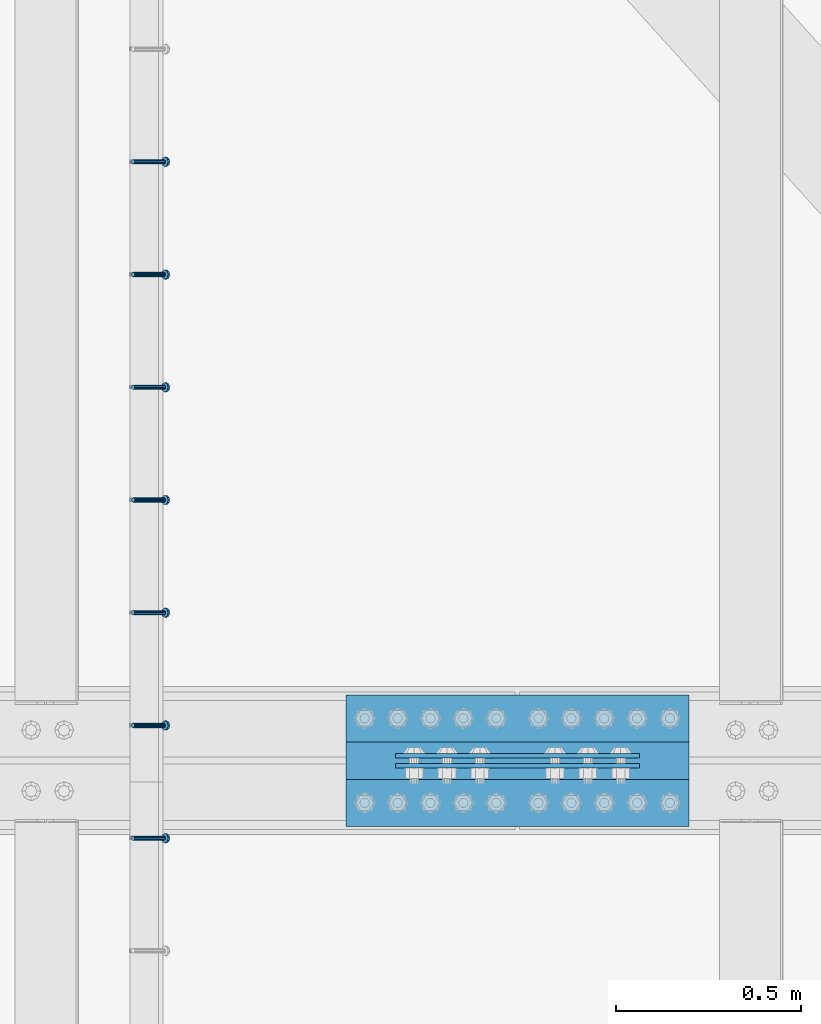
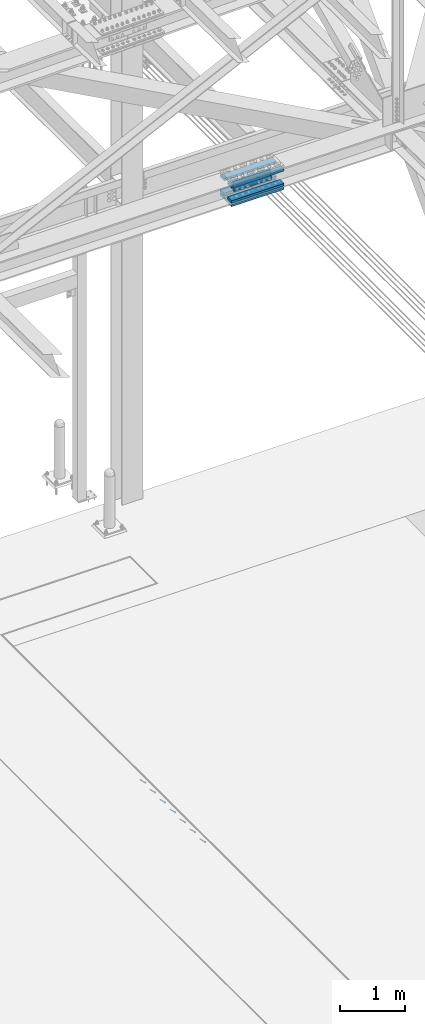
# One storey, part 2527 of 3843: 7 beams, 7 members, 3 elements without a shape of their own.
"""IFC2X3 building model written with IfcOpenShell, lengths in millimetres."""

from ifc_helpers import new_model, si_unit, frame, origin_with_axes, place, context, subcontext, project, spatial, faceted_brep, material, type_object, element, aggregate, save


model = new_model("IFC2X3")

# Units and contexts
model_context = context("Model", 3, precision=1e-05, world=origin_with_axes())
body_context = subcontext(model_context, "Body", "Model", "MODEL_VIEW")
ifc_project = project(units=[si_unit("LENGTHUNIT", "METRE", prefix="MILLI"), si_unit("AREAUNIT", "SQUARE_METRE"), si_unit("VOLUMEUNIT", "CUBIC_METRE"), si_unit("MASSUNIT", "GRAM", prefix="KILO"), si_unit("TIMEUNIT", "SECOND"), si_unit("PLANEANGLEUNIT", "RADIAN"), si_unit("SOLIDANGLEUNIT", "STERADIAN"), si_unit("THERMODYNAMICTEMPERATUREUNIT", "DEGREE_CELSIUS"), si_unit("LUMINOUSINTENSITYUNIT", "LUMEN")], contexts=[model_context])

# Site, building, storey
site_placement = place(None, origin_with_axes())
site = spatial("IfcSite", under=ifc_project, at=site_placement, CompositionType="ELEMENT")
building_placement = place(site_placement, origin_with_axes())
building = spatial("IfcBuilding", under=site, at=building_placement, Name="Undefined", CompositionType="ELEMENT")
storey_placement = place(building_placement, origin_with_axes())
storey = spatial("IfcBuildingStorey", under=building, at=storey_placement, Name="Undefined", CompositionType="ELEMENT", Elevation=0.0)

# Assembly, member
assembly_1_placement = place(storey_placement, origin_with_axes())
assembly_1 = element("IfcElementAssembly", 1, at=assembly_1_placement, inside=storey, Name="EMBED_ANGLE", AssemblyPlace="NOTDEFINED", PredefinedType="RIGID_FRAME")
ifc_material_1 = material(Name="STEEL/A108")
member_type = type_object("IfcMemberType", PredefinedType="NOTDEFINED")
member_1_placement = place(assembly_1_placement, frame((66677.3495, 83775.4227092285, 30446.6625), z_axis=(0.0, 1.0, 0.0), x_axis=(0.707106781186548, 0.0, -0.707106781186548)))
member_1 = element("IfcMember", 2, at=member_1_placement, type_object=member_type, material=ifc_material_1, Name="HEADED STUD ANCHOR", context=body_context, shape_type="Brep", body=[
    faceted_brep([(7.27595761418343e-12, -3.18000006675175, 5.5), (0.0, -5.49999999998363, 3.1800000667572), (118.110000000976, -5.49999999999091, 3.1800000667572), (118.110000000983, -3.18000006675175, 5.5), (0.0, -6.3499999046162, 0.0), (118.110000000968, -6.34999990461256, 0.0), (0.0, -5.49999999998363, -3.1800000667572), (118.110000000976, -5.49999999999091, -3.1800000667572), (7.27595761418343e-12, -3.18000006675175, -5.5), (118.110000000983, -3.18000006675175, -5.5), (7.27595761418343e-12, -1.81898940354586e-12, -6.34999990463257), (118.110000000968, -1.81898940354586e-12, -6.34999990463257), (0.0, 3.18000006675175, -5.5), (118.110000000968, 3.18000006674811, -5.5), (7.27595761418343e-12, 5.49999999998363, -3.1800000667572), (118.110000000983, 5.49999999998363, -3.1800000667572), (7.27595761418343e-12, 6.3499999046162, 0.0), (118.110000000976, 6.34999990461256, 0.0), (7.27595761418343e-12, 5.49999999998363, 3.1800000667572), (118.110000000983, 5.49999999998363, 3.1800000667572), (0.0, 3.18000006675175, 5.5), (118.110000000968, 3.18000006674811, 5.5), (7.27595761418343e-12, -1.81898940354586e-12, 6.34999990463257), (118.110000000968, -1.81898940354586e-12, 6.34999990463257), (120.650000000991, -10.9899997710909, 6.34999990463257), (120.650000000998, -6.34000015257152, 10.9899997711182), (120.650000000991, -12.6999998092379, 0.0), (120.650000000991, -10.9899997710909, -6.34999990463257), (120.650000000998, -6.34000015257152, -10.9899997711182), (120.650000000991, -1.81898940354586e-12, -12.6899995803833), (120.650000000991, 6.34000015257152, -10.9899997711182), (120.650000000998, 10.9899997710909, -6.34999990463257), (120.650000000991, 12.6999998092342, 0.0), (120.650000000998, 10.9899997710909, 6.34999990463257), (120.650000000991, 6.34000015257152, 10.9899997711182), (120.650000000991, -1.81898940354586e-12, 12.6899995803833), (127.000000001048, -10.9899997710945, 6.34999990463257), (127.000000001048, -6.34000015257152, 10.9899997711182), (127.000000001048, -12.6999998092342, 0.0), (127.000000001048, -10.9899997710945, -6.34999990463257), (127.000000001048, -6.34000015257152, -10.9899997711182), (127.000000001048, 1.81898940354586e-12, -12.6899995803833), (127.000000001048, 6.34000015256788, -10.9899997711182), (127.000000001048, 10.9899997710909, -6.34999990463257), (127.000000001048, 12.6999998092379, 0.0), (127.000000001048, 10.9899997710909, 6.34999990463257), (127.000000001048, 6.34000015256788, 10.9899997711182), (127.000000001048, 1.81898940354586e-12, 12.6899995803833)], [[[0, 1, 2, 3]], [[1, 4, 5, 2]], [[4, 6, 7, 5]], [[6, 8, 9, 7]], [[8, 10, 11, 9]], [[10, 12, 13, 11]], [[12, 14, 15, 13]], [[14, 16, 17, 15]], [[16, 18, 19, 17]], [[18, 20, 21, 19]], [[20, 22, 23, 21]], [[22, 0, 3, 23]], [[22, 20, 18, 16, 14, 12, 10, 8, 6, 4, 1, 0]], [[3, 2, 24, 25]], [[2, 5, 26, 24]], [[5, 7, 27, 26]], [[7, 9, 28, 27]], [[9, 11, 29, 28]], [[11, 13, 30, 29]], [[13, 15, 31, 30]], [[15, 17, 32, 31]], [[17, 19, 33, 32]], [[19, 21, 34, 33]], [[21, 23, 35, 34]], [[23, 3, 25, 35]], [[25, 24, 36, 37]], [[24, 26, 38, 36]], [[26, 27, 39, 38]], [[27, 28, 40, 39]], [[28, 29, 41, 40]], [[29, 30, 42, 41]], [[30, 31, 43, 42]], [[31, 32, 44, 43]], [[32, 33, 45, 44]], [[33, 34, 46, 45]], [[34, 35, 47, 46]], [[35, 25, 37, 47]], [[38, 39, 40, 41, 42, 43, 44, 45, 46, 47, 37, 36]]]),
])
aggregate(assembly_1, [member_1])

# Assembly, members
assembly_2_placement = place(storey_placement, origin_with_axes())
assembly_2 = element("IfcElementAssembly", 3, at=assembly_2_placement, inside=storey, Name="EMBED_ANGLE", AssemblyPlace="NOTDEFINED", PredefinedType="RIGID_FRAME")
member_2_placement = place(assembly_2_placement, frame((66677.3495, 84080.2227092285, 30446.6625), z_axis=(0.0, 1.0, 0.0), x_axis=(0.707106781186548, 0.0, -0.707106781186548)))
member_2 = element("IfcMember", 4, at=member_2_placement, type_object=member_type, material=ifc_material_1, Name="HEADED STUD ANCHOR", context=body_context, shape_type="Brep", body=[
    faceted_brep([(7.27595761418343e-12, -3.18000006675175, 5.5), (0.0, -5.49999999998363, 3.1800000667572), (118.110000000976, -5.49999999999091, 3.1800000667572), (118.110000000983, -3.18000006675175, 5.5), (0.0, -6.3499999046162, 0.0), (118.110000000968, -6.34999990461256, 0.0), (0.0, -5.49999999998363, -3.1800000667572), (118.110000000976, -5.49999999999091, -3.1800000667572), (7.27595761418343e-12, -3.18000006675175, -5.5), (118.110000000983, -3.18000006675175, -5.5), (7.27595761418343e-12, -1.81898940354586e-12, -6.34999990463257), (118.110000000968, -1.81898940354586e-12, -6.34999990463257), (0.0, 3.18000006675175, -5.5), (118.110000000968, 3.18000006674811, -5.5), (7.27595761418343e-12, 5.49999999998363, -3.1800000667572), (118.110000000983, 5.49999999998363, -3.1800000667572), (7.27595761418343e-12, 6.3499999046162, 0.0), (118.110000000976, 6.34999990461256, 0.0), (7.27595761418343e-12, 5.49999999998363, 3.1800000667572), (118.110000000983, 5.49999999998363, 3.1800000667572), (0.0, 3.18000006675175, 5.5), (118.110000000968, 3.18000006674811, 5.5), (7.27595761418343e-12, -1.81898940354586e-12, 6.34999990463257), (118.110000000968, -1.81898940354586e-12, 6.34999990463257), (120.650000000991, -10.9899997710909, 6.34999990463257), (120.650000000998, -6.34000015257152, 10.9899997711182), (120.650000000991, -12.6999998092379, 0.0), (120.650000000991, -10.9899997710909, -6.34999990463257), (120.650000000998, -6.34000015257152, -10.9899997711182), (120.650000000991, -1.81898940354586e-12, -12.6899995803833), (120.650000000991, 6.34000015257152, -10.9899997711182), (120.650000000998, 10.9899997710909, -6.34999990463257), (120.650000000991, 12.6999998092342, 0.0), (120.650000000998, 10.9899997710909, 6.34999990463257), (120.650000000991, 6.34000015257152, 10.9899997711182), (120.650000000991, -1.81898940354586e-12, 12.6899995803833), (127.000000001048, -10.9899997710945, 6.34999990463257), (127.000000001048, -6.34000015257152, 10.9899997711182), (127.000000001048, -12.6999998092342, 0.0), (127.000000001048, -10.9899997710945, -6.34999990463257), (127.000000001048, -6.34000015257152, -10.9899997711182), (127.000000001048, 1.81898940354586e-12, -12.6899995803833), (127.000000001048, 6.34000015256788, -10.9899997711182), (127.000000001048, 10.9899997710909, -6.34999990463257), (127.000000001048, 12.6999998092379, 0.0), (127.000000001048, 10.9899997710909, 6.34999990463257), (127.000000001048, 6.34000015256788, 10.9899997711182), (127.000000001048, 1.81898940354586e-12, 12.6899995803833)], [[[0, 1, 2, 3]], [[1, 4, 5, 2]], [[4, 6, 7, 5]], [[6, 8, 9, 7]], [[8, 10, 11, 9]], [[10, 12, 13, 11]], [[12, 14, 15, 13]], [[14, 16, 17, 15]], [[16, 18, 19, 17]], [[18, 20, 21, 19]], [[20, 22, 23, 21]], [[22, 0, 3, 23]], [[22, 20, 18, 16, 14, 12, 10, 8, 6, 4, 1, 0]], [[3, 2, 24, 25]], [[2, 5, 26, 24]], [[5, 7, 27, 26]], [[7, 9, 28, 27]], [[9, 11, 29, 28]], [[11, 13, 30, 29]], [[13, 15, 31, 30]], [[15, 17, 32, 31]], [[17, 19, 33, 32]], [[19, 21, 34, 33]], [[21, 23, 35, 34]], [[23, 3, 25, 35]], [[25, 24, 36, 37]], [[24, 26, 38, 36]], [[26, 27, 39, 38]], [[27, 28, 40, 39]], [[28, 29, 41, 40]], [[29, 30, 42, 41]], [[30, 31, 43, 42]], [[31, 32, 44, 43]], [[32, 33, 45, 44]], [[33, 34, 46, 45]], [[34, 35, 47, 46]], [[35, 25, 37, 47]], [[38, 39, 40, 41, 42, 43, 44, 45, 46, 47, 37, 36]]]),
])
member_3_placement = place(assembly_2_placement, frame((66677.3495, 84385.0227092285, 30446.6625), z_axis=(0.0, 1.0, 0.0), x_axis=(0.707106781186548, 0.0, -0.707106781186548)))
member_3 = element("IfcMember", 5, at=member_3_placement, type_object=member_type, material=ifc_material_1, Name="HEADED STUD ANCHOR", context=body_context, shape_type="Brep", body=[
    faceted_brep([(7.27595761418343e-12, -3.18000006675175, 5.5), (0.0, -5.49999999998363, 3.1800000667572), (118.110000000976, -5.49999999999091, 3.1800000667572), (118.110000000983, -3.18000006675175, 5.5), (0.0, -6.3499999046162, 0.0), (118.110000000968, -6.34999990461256, 0.0), (0.0, -5.49999999998363, -3.1800000667572), (118.110000000976, -5.49999999999091, -3.1800000667572), (7.27595761418343e-12, -3.18000006675175, -5.5), (118.110000000983, -3.18000006675175, -5.5), (7.27595761418343e-12, -1.81898940354586e-12, -6.34999990463257), (118.110000000968, -1.81898940354586e-12, -6.34999990463257), (0.0, 3.18000006675175, -5.5), (118.110000000968, 3.18000006674811, -5.5), (7.27595761418343e-12, 5.49999999998363, -3.1800000667572), (118.110000000983, 5.49999999998363, -3.1800000667572), (7.27595761418343e-12, 6.3499999046162, 0.0), (118.110000000976, 6.34999990461256, 0.0), (7.27595761418343e-12, 5.49999999998363, 3.1800000667572), (118.110000000983, 5.49999999998363, 3.1800000667572), (0.0, 3.18000006675175, 5.5), (118.110000000968, 3.18000006674811, 5.5), (7.27595761418343e-12, -1.81898940354586e-12, 6.34999990463257), (118.110000000968, -1.81898940354586e-12, 6.34999990463257), (120.650000000991, -10.9899997710909, 6.34999990463257), (120.650000000998, -6.34000015257152, 10.9899997711182), (120.650000000991, -12.6999998092379, 0.0), (120.650000000991, -10.9899997710909, -6.34999990463257), (120.650000000998, -6.34000015257152, -10.9899997711182), (120.650000000991, -1.81898940354586e-12, -12.6899995803833), (120.650000000991, 6.34000015257152, -10.9899997711182), (120.650000000998, 10.9899997710909, -6.34999990463257), (120.650000000991, 12.6999998092342, 0.0), (120.650000000998, 10.9899997710909, 6.34999990463257), (120.650000000991, 6.34000015257152, 10.9899997711182), (120.650000000991, -1.81898940354586e-12, 12.6899995803833), (127.000000001048, -10.9899997710945, 6.34999990463257), (127.000000001048, -6.34000015257152, 10.9899997711182), (127.000000001048, -12.6999998092342, 0.0), (127.000000001048, -10.9899997710945, -6.34999990463257), (127.000000001048, -6.34000015257152, -10.9899997711182), (127.000000001048, 1.81898940354586e-12, -12.6899995803833), (127.000000001048, 6.34000015256788, -10.9899997711182), (127.000000001048, 10.9899997710909, -6.34999990463257), (127.000000001048, 12.6999998092379, 0.0), (127.000000001048, 10.9899997710909, 6.34999990463257), (127.000000001048, 6.34000015256788, 10.9899997711182), (127.000000001048, 1.81898940354586e-12, 12.6899995803833)], [[[0, 1, 2, 3]], [[1, 4, 5, 2]], [[4, 6, 7, 5]], [[6, 8, 9, 7]], [[8, 10, 11, 9]], [[10, 12, 13, 11]], [[12, 14, 15, 13]], [[14, 16, 17, 15]], [[16, 18, 19, 17]], [[18, 20, 21, 19]], [[20, 22, 23, 21]], [[22, 0, 3, 23]], [[22, 20, 18, 16, 14, 12, 10, 8, 6, 4, 1, 0]], [[3, 2, 24, 25]], [[2, 5, 26, 24]], [[5, 7, 27, 26]], [[7, 9, 28, 27]], [[9, 11, 29, 28]], [[11, 13, 30, 29]], [[13, 15, 31, 30]], [[15, 17, 32, 31]], [[17, 19, 33, 32]], [[19, 21, 34, 33]], [[21, 23, 35, 34]], [[23, 3, 25, 35]], [[25, 24, 36, 37]], [[24, 26, 38, 36]], [[26, 27, 39, 38]], [[27, 28, 40, 39]], [[28, 29, 41, 40]], [[29, 30, 42, 41]], [[30, 31, 43, 42]], [[31, 32, 44, 43]], [[32, 33, 45, 44]], [[33, 34, 46, 45]], [[34, 35, 47, 46]], [[35, 25, 37, 47]], [[38, 39, 40, 41, 42, 43, 44, 45, 46, 47, 37, 36]]]),
])
member_4_placement = place(assembly_2_placement, frame((66677.3495, 84689.8227092285, 30446.6625), z_axis=(0.0, 1.0, 0.0), x_axis=(0.707106781186548, 0.0, -0.707106781186548)))
member_4 = element("IfcMember", 6, at=member_4_placement, type_object=member_type, material=ifc_material_1, Name="HEADED STUD ANCHOR", context=body_context, shape_type="Brep", body=[
    faceted_brep([(7.27595761418343e-12, -3.18000006675175, 5.5), (0.0, -5.49999999998363, 3.1800000667572), (118.110000000976, -5.49999999999091, 3.1800000667572), (118.110000000983, -3.18000006675175, 5.5), (0.0, -6.3499999046162, 0.0), (118.110000000968, -6.34999990461256, 0.0), (0.0, -5.49999999998363, -3.1800000667572), (118.110000000976, -5.49999999999091, -3.1800000667572), (7.27595761418343e-12, -3.18000006675175, -5.5), (118.110000000983, -3.18000006675175, -5.5), (7.27595761418343e-12, -1.81898940354586e-12, -6.34999990463257), (118.110000000968, -1.81898940354586e-12, -6.34999990463257), (0.0, 3.18000006675175, -5.5), (118.110000000968, 3.18000006674811, -5.5), (7.27595761418343e-12, 5.49999999998363, -3.1800000667572), (118.110000000983, 5.49999999998363, -3.1800000667572), (7.27595761418343e-12, 6.3499999046162, 0.0), (118.110000000976, 6.34999990461256, 0.0), (7.27595761418343e-12, 5.49999999998363, 3.1800000667572), (118.110000000983, 5.49999999998363, 3.1800000667572), (0.0, 3.18000006675175, 5.5), (118.110000000968, 3.18000006674811, 5.5), (7.27595761418343e-12, -1.81898940354586e-12, 6.34999990463257), (118.110000000968, -1.81898940354586e-12, 6.34999990463257), (120.650000000991, -10.9899997710909, 6.34999990463257), (120.650000000998, -6.34000015257152, 10.9899997711182), (120.650000000991, -12.6999998092379, 0.0), (120.650000000991, -10.9899997710909, -6.34999990463257), (120.650000000998, -6.34000015257152, -10.9899997711182), (120.650000000991, -1.81898940354586e-12, -12.6899995803833), (120.650000000991, 6.34000015257152, -10.9899997711182), (120.650000000998, 10.9899997710909, -6.34999990463257), (120.650000000991, 12.6999998092342, 0.0), (120.650000000998, 10.9899997710909, 6.34999990463257), (120.650000000991, 6.34000015257152, 10.9899997711182), (120.650000000991, -1.81898940354586e-12, 12.6899995803833), (127.000000001048, -10.9899997710945, 6.34999990463257), (127.000000001048, -6.34000015257152, 10.9899997711182), (127.000000001048, -12.6999998092342, 0.0), (127.000000001048, -10.9899997710945, -6.34999990463257), (127.000000001048, -6.34000015257152, -10.9899997711182), (127.000000001048, 1.81898940354586e-12, -12.6899995803833), (127.000000001048, 6.34000015256788, -10.9899997711182), (127.000000001048, 10.9899997710909, -6.34999990463257), (127.000000001048, 12.6999998092379, 0.0), (127.000000001048, 10.9899997710909, 6.34999990463257), (127.000000001048, 6.34000015256788, 10.9899997711182), (127.000000001048, 1.81898940354586e-12, 12.6899995803833)], [[[0, 1, 2, 3]], [[1, 4, 5, 2]], [[4, 6, 7, 5]], [[6, 8, 9, 7]], [[8, 10, 11, 9]], [[10, 12, 13, 11]], [[12, 14, 15, 13]], [[14, 16, 17, 15]], [[16, 18, 19, 17]], [[18, 20, 21, 19]], [[20, 22, 23, 21]], [[22, 0, 3, 23]], [[22, 20, 18, 16, 14, 12, 10, 8, 6, 4, 1, 0]], [[3, 2, 24, 25]], [[2, 5, 26, 24]], [[5, 7, 27, 26]], [[7, 9, 28, 27]], [[9, 11, 29, 28]], [[11, 13, 30, 29]], [[13, 15, 31, 30]], [[15, 17, 32, 31]], [[17, 19, 33, 32]], [[19, 21, 34, 33]], [[21, 23, 35, 34]], [[23, 3, 25, 35]], [[25, 24, 36, 37]], [[24, 26, 38, 36]], [[26, 27, 39, 38]], [[27, 28, 40, 39]], [[28, 29, 41, 40]], [[29, 30, 42, 41]], [[30, 31, 43, 42]], [[31, 32, 44, 43]], [[32, 33, 45, 44]], [[33, 34, 46, 45]], [[34, 35, 47, 46]], [[35, 25, 37, 47]], [[38, 39, 40, 41, 42, 43, 44, 45, 46, 47, 37, 36]]]),
])
member_5_placement = place(assembly_2_placement, frame((66677.3495, 84994.6227092285, 30446.6625), z_axis=(0.0, 1.0, 0.0), x_axis=(0.707106781186548, 0.0, -0.707106781186548)))
member_5 = element("IfcMember", 7, at=member_5_placement, type_object=member_type, material=ifc_material_1, Name="HEADED STUD ANCHOR", context=body_context, shape_type="Brep", body=[
    faceted_brep([(7.27595761418343e-12, -3.18000006675175, 5.5), (0.0, -5.49999999998363, 3.1800000667572), (118.110000000976, -5.49999999999091, 3.1800000667572), (118.110000000983, -3.18000006675175, 5.5), (0.0, -6.3499999046162, 0.0), (118.110000000968, -6.34999990461256, 0.0), (0.0, -5.49999999998363, -3.1800000667572), (118.110000000976, -5.49999999999091, -3.1800000667572), (7.27595761418343e-12, -3.18000006675175, -5.5), (118.110000000983, -3.18000006675175, -5.5), (7.27595761418343e-12, -1.81898940354586e-12, -6.34999990463257), (118.110000000968, -1.81898940354586e-12, -6.34999990463257), (0.0, 3.18000006675175, -5.5), (118.110000000968, 3.18000006674811, -5.5), (7.27595761418343e-12, 5.49999999998363, -3.1800000667572), (118.110000000983, 5.49999999998363, -3.1800000667572), (7.27595761418343e-12, 6.3499999046162, 0.0), (118.110000000976, 6.34999990461256, 0.0), (7.27595761418343e-12, 5.49999999998363, 3.1800000667572), (118.110000000983, 5.49999999998363, 3.1800000667572), (0.0, 3.18000006675175, 5.5), (118.110000000968, 3.18000006674811, 5.5), (7.27595761418343e-12, -1.81898940354586e-12, 6.34999990463257), (118.110000000968, -1.81898940354586e-12, 6.34999990463257), (120.650000000991, -10.9899997710909, 6.34999990463257), (120.650000000998, -6.34000015257152, 10.9899997711182), (120.650000000991, -12.6999998092379, 0.0), (120.650000000991, -10.9899997710909, -6.34999990463257), (120.650000000998, -6.34000015257152, -10.9899997711182), (120.650000000991, -1.81898940354586e-12, -12.6899995803833), (120.650000000991, 6.34000015257152, -10.9899997711182), (120.650000000998, 10.9899997710909, -6.34999990463257), (120.650000000991, 12.6999998092342, 0.0), (120.650000000998, 10.9899997710909, 6.34999990463257), (120.650000000991, 6.34000015257152, 10.9899997711182), (120.650000000991, -1.81898940354586e-12, 12.6899995803833), (127.000000001048, -10.9899997710945, 6.34999990463257), (127.000000001048, -6.34000015257152, 10.9899997711182), (127.000000001048, -12.6999998092342, 0.0), (127.000000001048, -10.9899997710945, -6.34999990463257), (127.000000001048, -6.34000015257152, -10.9899997711182), (127.000000001048, 1.81898940354586e-12, -12.6899995803833), (127.000000001048, 6.34000015256788, -10.9899997711182), (127.000000001048, 10.9899997710909, -6.34999990463257), (127.000000001048, 12.6999998092379, 0.0), (127.000000001048, 10.9899997710909, 6.34999990463257), (127.000000001048, 6.34000015256788, 10.9899997711182), (127.000000001048, 1.81898940354586e-12, 12.6899995803833)], [[[0, 1, 2, 3]], [[1, 4, 5, 2]], [[4, 6, 7, 5]], [[6, 8, 9, 7]], [[8, 10, 11, 9]], [[10, 12, 13, 11]], [[12, 14, 15, 13]], [[14, 16, 17, 15]], [[16, 18, 19, 17]], [[18, 20, 21, 19]], [[20, 22, 23, 21]], [[22, 0, 3, 23]], [[22, 20, 18, 16, 14, 12, 10, 8, 6, 4, 1, 0]], [[3, 2, 24, 25]], [[2, 5, 26, 24]], [[5, 7, 27, 26]], [[7, 9, 28, 27]], [[9, 11, 29, 28]], [[11, 13, 30, 29]], [[13, 15, 31, 30]], [[15, 17, 32, 31]], [[17, 19, 33, 32]], [[19, 21, 34, 33]], [[21, 23, 35, 34]], [[23, 3, 25, 35]], [[25, 24, 36, 37]], [[24, 26, 38, 36]], [[26, 27, 39, 38]], [[27, 28, 40, 39]], [[28, 29, 41, 40]], [[29, 30, 42, 41]], [[30, 31, 43, 42]], [[31, 32, 44, 43]], [[32, 33, 45, 44]], [[33, 34, 46, 45]], [[34, 35, 47, 46]], [[35, 25, 37, 47]], [[38, 39, 40, 41, 42, 43, 44, 45, 46, 47, 37, 36]]]),
])
member_6_placement = place(assembly_2_placement, frame((66677.3495, 85299.4227092285, 30446.6625), z_axis=(0.0, 1.0, 0.0), x_axis=(0.707106781186548, 0.0, -0.707106781186548)))
member_6 = element("IfcMember", 8, at=member_6_placement, type_object=member_type, material=ifc_material_1, Name="HEADED STUD ANCHOR", context=body_context, shape_type="Brep", body=[
    faceted_brep([(7.27595761418343e-12, -3.18000006675175, 5.5), (0.0, -5.49999999998363, 3.1800000667572), (118.110000000976, -5.49999999999091, 3.1800000667572), (118.110000000983, -3.18000006675175, 5.5), (0.0, -6.3499999046162, 0.0), (118.110000000968, -6.34999990461256, 0.0), (0.0, -5.49999999998363, -3.1800000667572), (118.110000000976, -5.49999999999091, -3.1800000667572), (7.27595761418343e-12, -3.18000006675175, -5.5), (118.110000000983, -3.18000006675175, -5.5), (7.27595761418343e-12, -1.81898940354586e-12, -6.34999990463257), (118.110000000968, -1.81898940354586e-12, -6.34999990463257), (0.0, 3.18000006675175, -5.5), (118.110000000968, 3.18000006674811, -5.5), (7.27595761418343e-12, 5.49999999998363, -3.1800000667572), (118.110000000983, 5.49999999998363, -3.1800000667572), (7.27595761418343e-12, 6.3499999046162, 0.0), (118.110000000976, 6.34999990461256, 0.0), (7.27595761418343e-12, 5.49999999998363, 3.1800000667572), (118.110000000983, 5.49999999998363, 3.1800000667572), (0.0, 3.18000006675175, 5.5), (118.110000000968, 3.18000006674811, 5.5), (7.27595761418343e-12, -1.81898940354586e-12, 6.34999990463257), (118.110000000968, -1.81898940354586e-12, 6.34999990463257), (120.650000000991, -10.9899997710909, 6.34999990463257), (120.650000000998, -6.34000015257152, 10.9899997711182), (120.650000000991, -12.6999998092379, 0.0), (120.650000000991, -10.9899997710909, -6.34999990463257), (120.650000000998, -6.34000015257152, -10.9899997711182), (120.650000000991, -1.81898940354586e-12, -12.6899995803833), (120.650000000991, 6.34000015257152, -10.9899997711182), (120.650000000998, 10.9899997710909, -6.34999990463257), (120.650000000991, 12.6999998092342, 0.0), (120.650000000998, 10.9899997710909, 6.34999990463257), (120.650000000991, 6.34000015257152, 10.9899997711182), (120.650000000991, -1.81898940354586e-12, 12.6899995803833), (127.000000001048, -10.9899997710945, 6.34999990463257), (127.000000001048, -6.34000015257152, 10.9899997711182), (127.000000001048, -12.6999998092342, 0.0), (127.000000001048, -10.9899997710945, -6.34999990463257), (127.000000001048, -6.34000015257152, -10.9899997711182), (127.000000001048, 1.81898940354586e-12, -12.6899995803833), (127.000000001048, 6.34000015256788, -10.9899997711182), (127.000000001048, 10.9899997710909, -6.34999990463257), (127.000000001048, 12.6999998092379, 0.0), (127.000000001048, 10.9899997710909, 6.34999990463257), (127.000000001048, 6.34000015256788, 10.9899997711182), (127.000000001048, 1.81898940354586e-12, 12.6899995803833)], [[[0, 1, 2, 3]], [[1, 4, 5, 2]], [[4, 6, 7, 5]], [[6, 8, 9, 7]], [[8, 10, 11, 9]], [[10, 12, 13, 11]], [[12, 14, 15, 13]], [[14, 16, 17, 15]], [[16, 18, 19, 17]], [[18, 20, 21, 19]], [[20, 22, 23, 21]], [[22, 0, 3, 23]], [[22, 20, 18, 16, 14, 12, 10, 8, 6, 4, 1, 0]], [[3, 2, 24, 25]], [[2, 5, 26, 24]], [[5, 7, 27, 26]], [[7, 9, 28, 27]], [[9, 11, 29, 28]], [[11, 13, 30, 29]], [[13, 15, 31, 30]], [[15, 17, 32, 31]], [[17, 19, 33, 32]], [[19, 21, 34, 33]], [[21, 23, 35, 34]], [[23, 3, 25, 35]], [[25, 24, 36, 37]], [[24, 26, 38, 36]], [[26, 27, 39, 38]], [[27, 28, 40, 39]], [[28, 29, 41, 40]], [[29, 30, 42, 41]], [[30, 31, 43, 42]], [[31, 32, 44, 43]], [[32, 33, 45, 44]], [[33, 34, 46, 45]], [[34, 35, 47, 46]], [[35, 25, 37, 47]], [[38, 39, 40, 41, 42, 43, 44, 45, 46, 47, 37, 36]]]),
])
member_7_placement = place(assembly_2_placement, frame((66677.3495, 85604.2227092285, 30446.6625), z_axis=(0.0, 1.0, 0.0), x_axis=(0.707106781186548, 0.0, -0.707106781186548)))
member_7 = element("IfcMember", 9, at=member_7_placement, type_object=member_type, material=ifc_material_1, Name="HEADED STUD ANCHOR", context=body_context, shape_type="Brep", body=[
    faceted_brep([(7.27595761418343e-12, -3.18000006675175, 5.5), (0.0, -5.49999999998363, 3.1800000667572), (118.110000000976, -5.49999999999091, 3.1800000667572), (118.110000000983, -3.18000006675175, 5.5), (0.0, -6.3499999046162, 0.0), (118.110000000968, -6.34999990461256, 0.0), (0.0, -5.49999999998363, -3.1800000667572), (118.110000000976, -5.49999999999091, -3.1800000667572), (7.27595761418343e-12, -3.18000006675175, -5.5), (118.110000000983, -3.18000006675175, -5.5), (7.27595761418343e-12, -1.81898940354586e-12, -6.34999990463257), (118.110000000968, -1.81898940354586e-12, -6.34999990463257), (0.0, 3.18000006675175, -5.5), (118.110000000968, 3.18000006674811, -5.5), (7.27595761418343e-12, 5.49999999998363, -3.1800000667572), (118.110000000983, 5.49999999998363, -3.1800000667572), (7.27595761418343e-12, 6.3499999046162, 0.0), (118.110000000976, 6.34999990461256, 0.0), (7.27595761418343e-12, 5.49999999998363, 3.1800000667572), (118.110000000983, 5.49999999998363, 3.1800000667572), (0.0, 3.18000006675175, 5.5), (118.110000000968, 3.18000006674811, 5.5), (7.27595761418343e-12, -1.81898940354586e-12, 6.34999990463257), (118.110000000968, -1.81898940354586e-12, 6.34999990463257), (120.650000000991, -10.9899997710909, 6.34999990463257), (120.650000000998, -6.34000015257152, 10.9899997711182), (120.650000000991, -12.6999998092379, 0.0), (120.650000000991, -10.9899997710909, -6.34999990463257), (120.650000000998, -6.34000015257152, -10.9899997711182), (120.650000000991, -1.81898940354586e-12, -12.6899995803833), (120.650000000991, 6.34000015257152, -10.9899997711182), (120.650000000998, 10.9899997710909, -6.34999990463257), (120.650000000991, 12.6999998092342, 0.0), (120.650000000998, 10.9899997710909, 6.34999990463257), (120.650000000991, 6.34000015257152, 10.9899997711182), (120.650000000991, -1.81898940354586e-12, 12.6899995803833), (127.000000001048, -10.9899997710945, 6.34999990463257), (127.000000001048, -6.34000015257152, 10.9899997711182), (127.000000001048, -12.6999998092342, 0.0), (127.000000001048, -10.9899997710945, -6.34999990463257), (127.000000001048, -6.34000015257152, -10.9899997711182), (127.000000001048, 1.81898940354586e-12, -12.6899995803833), (127.000000001048, 6.34000015256788, -10.9899997711182), (127.000000001048, 10.9899997710909, -6.34999990463257), (127.000000001048, 12.6999998092379, 0.0), (127.000000001048, 10.9899997710909, 6.34999990463257), (127.000000001048, 6.34000015256788, 10.9899997711182), (127.000000001048, 1.81898940354586e-12, 12.6899995803833)], [[[0, 1, 2, 3]], [[1, 4, 5, 2]], [[4, 6, 7, 5]], [[6, 8, 9, 7]], [[8, 10, 11, 9]], [[10, 12, 13, 11]], [[12, 14, 15, 13]], [[14, 16, 17, 15]], [[16, 18, 19, 17]], [[18, 20, 21, 19]], [[20, 22, 23, 21]], [[22, 0, 3, 23]], [[22, 20, 18, 16, 14, 12, 10, 8, 6, 4, 1, 0]], [[3, 2, 24, 25]], [[2, 5, 26, 24]], [[5, 7, 27, 26]], [[7, 9, 28, 27]], [[9, 11, 29, 28]], [[11, 13, 30, 29]], [[13, 15, 31, 30]], [[15, 17, 32, 31]], [[17, 19, 33, 32]], [[19, 21, 34, 33]], [[21, 23, 35, 34]], [[23, 3, 25, 35]], [[25, 24, 36, 37]], [[24, 26, 38, 36]], [[26, 27, 39, 38]], [[27, 28, 40, 39]], [[28, 29, 41, 40]], [[29, 30, 42, 41]], [[30, 31, 43, 42]], [[31, 32, 44, 43]], [[32, 33, 45, 44]], [[33, 34, 46, 45]], [[34, 35, 47, 46]], [[35, 25, 37, 47]], [[38, 39, 40, 41, 42, 43, 44, 45, 46, 47, 37, 36]]]),
])
aggregate(assembly_2, [member_2, member_3, member_4, member_5, member_6, member_7])

# Assembly, beams
assembly_3_placement = place(storey_placement, origin_with_axes())
assembly_3 = element("IfcElementAssembly", 10, at=assembly_3_placement, inside=storey, Name="BEAM", AssemblyPlace="NOTDEFINED", PredefinedType="RIGID_FRAME")
ifc_material_2 = material(Name="STEEL/A572-50")
beam_type_1 = type_object("IfcBeamType", PredefinedType="NOTDEFINED")
beam_1_placement = place(assembly_3_placement, frame((68046.5999614954, 83971.60625, 42261.7444839287), z_axis=(-0.00048281500021403, 0.0, 0.999999883444831), x_axis=(-0.999999883445314, 0.0, -0.000482814000210543)))
beam_1 = element("IfcBeam", 11, at=beam_1_placement, type_object=beam_type_1, material=ifc_material_2, Name="PLATE", context=body_context, shape_type="Brep", body=[
    faceted_brep([(1.45519152283669e-11, 6.35000000000582, -88.8999999998996), (0.0, 6.34999999999854, 88.9000015258789), (660.399999982677, 6.35000000000582, 88.8999999999651), (660.399999982707, 6.35000000000582, -88.8999999998268), (0.0, -6.34999999999854, 88.9000015258789), (660.399999982677, -6.35000000000582, 88.8999999999651), (1.45519152283669e-11, -6.35000000000582, -88.8999999998996), (660.399999982707, -6.35000000000582, -88.8999999998268)], [[[0, 1, 2, 3]], [[1, 4, 5, 2]], [[4, 6, 7, 5]], [[6, 0, 3, 7]], [[5, 7, 3, 2]], [[6, 4, 1, 0]]]),
])
beam_2_placement = place(assembly_3_placement, frame((68046.5999614954, 83998.59375, 42261.7444839287), z_axis=(-0.00048281500021403, 0.0, 0.999999883444831), x_axis=(-0.999999883445314, 0.0, -0.000482814000210543)))
beam_2 = element("IfcBeam", 12, at=beam_2_placement, type_object=beam_type_1, material=ifc_material_2, Name="PLATE", context=body_context, shape_type="Brep", body=[
    faceted_brep([(1.45519152283669e-11, 6.35000000000582, -88.8999999998996), (0.0, 6.34999999999854, 88.9000015258789), (660.399999982677, 6.35000000000582, 88.8999999999651), (660.399999982707, 6.35000000000582, -88.8999999998268), (0.0, -6.34999999999854, 88.9000015258789), (660.399999982677, -6.35000000000582, 88.8999999999651), (1.45519152283669e-11, -6.35000000000582, -88.8999999998996), (660.399999982707, -6.35000000000582, -88.8999999998268)], [[[0, 1, 2, 3]], [[1, 4, 5, 2]], [[4, 6, 7, 5]], [[6, 0, 3, 7]], [[5, 7, 3, 2]], [[6, 4, 1, 0]]]),
])
beam_type_2 = type_object("IfcBeamType", PredefinedType="NOTDEFINED")
beam_3_placement = place(assembly_3_placement, frame((68180.0495866912, 83985.1, 42055.4338910945), z_axis=(0.0, 1.0, 0.0), x_axis=(-0.999999883445314, 0.0, -0.000482814000210543)))
beam_3 = element("IfcBeam", 13, at=beam_3_placement, type_object=beam_type_2, material=ifc_material_2, Name="PLATE", context=body_context, shape_type="Brep", body=[
    faceted_brep([(0.0, 22.2249999999767, -177.800000000003), (0.0, 22.2249999999767, 177.800000000003), (927.099999958984, 22.2250000000859, 177.800000000003), (927.099999958984, 22.2250000000859, -177.800000000003), (0.0, -22.2249999999694, 177.800000000003), (927.099999958984, -22.2249999998749, 177.800000000003), (0.0, -22.2249999999694, -177.800000000003), (927.099999958984, -22.2249999998749, -177.800000000003)], [[[0, 1, 2, 3]], [[1, 4, 5, 2]], [[4, 6, 7, 5]], [[6, 0, 3, 7]], [[5, 7, 3, 2]], [[6, 4, 1, 0]]]),
])
beam_type_3 = type_object("IfcBeamType", PredefinedType="NOTDEFINED")
beam_4_placement = place(assembly_3_placement, frame((67252.9167367026, 83870.8, 42123.2487664279), z_axis=(0.0, 1.0, 0.0), x_axis=(0.999999883444831, 0.0, 0.000482815000217081)))
beam_4 = element("IfcBeam", 14, at=beam_4_placement, type_object=beam_type_3, material=ifc_material_2, Name="PLATE", context=body_context, shape_type="Brep", body=[
    faceted_brep([(-7.27595761418343e-11, 22.2250000000786, -63.5), (-7.27595761418343e-11, 22.2250000000786, 63.5), (927.099999951592, 22.2250000031054, 63.5), (927.099999951592, 22.2250000031054, -63.5), (6.54836185276508e-11, -22.2250000000713, 63.5), (927.099999951744, -22.2249999970372, 63.5), (6.54836185276508e-11, -22.2250000000713, -63.5), (927.099999951744, -22.2249999970372, -63.5)], [[[0, 1, 2, 3]], [[1, 4, 5, 2]], [[4, 6, 7, 5]], [[6, 0, 3, 7]], [[5, 7, 3, 2]], [[6, 4, 1, 0]]]),
])
beam_5_placement = place(assembly_3_placement, frame((67252.7833713996, 83870.8, 42399.4737342395), z_axis=(0.0, 1.0, 0.0), x_axis=(0.999999883444831, 0.0, 0.000482815000217081)))
beam_5 = element("IfcBeam", 15, at=beam_5_placement, type_object=beam_type_3, material=ifc_material_2, Name="PLATE", context=body_context, shape_type="Brep", body=[
    faceted_brep([(-7.27595761418343e-11, 22.2250000000786, -63.5), (-7.27595761418343e-11, 22.2250000000786, 63.5), (927.099999951592, 22.2250000031054, 63.5), (927.099999951592, 22.2250000031054, -63.5), (6.54836185276508e-11, -22.2250000000713, 63.5), (927.099999951744, -22.2249999970372, 63.5), (6.54836185276508e-11, -22.2250000000713, -63.5), (927.099999951744, -22.2249999970372, -63.5)], [[[0, 1, 2, 3]], [[1, 4, 5, 2]], [[4, 6, 7, 5]], [[6, 0, 3, 7]], [[5, 7, 3, 2]], [[6, 4, 1, 0]]]),
])
beam_6_placement = place(assembly_3_placement, frame((67252.9167367026, 84099.4, 42123.2487664279), z_axis=(0.0, 1.0, 0.0), x_axis=(0.999999883444831, 0.0, 0.000482815000217081)))
beam_6 = element("IfcBeam", 16, at=beam_6_placement, type_object=beam_type_3, material=ifc_material_2, Name="PLATE", context=body_context, shape_type="Brep", body=[
    faceted_brep([(-7.27595761418343e-11, 22.2250000000786, -63.5), (-7.27595761418343e-11, 22.2250000000786, 63.5), (927.099999951592, 22.2250000031054, 63.5), (927.099999951592, 22.2250000031054, -63.5), (6.54836185276508e-11, -22.2250000000713, 63.5), (927.099999951744, -22.2249999970372, 63.5), (6.54836185276508e-11, -22.2250000000713, -63.5), (927.099999951744, -22.2249999970372, -63.5)], [[[0, 1, 2, 3]], [[1, 4, 5, 2]], [[4, 6, 7, 5]], [[6, 0, 3, 7]], [[5, 7, 3, 2]], [[6, 4, 1, 0]]]),
])
beam_7_placement = place(assembly_3_placement, frame((67252.7833713996, 84099.4, 42399.4737342395), z_axis=(0.0, 1.0, 0.0), x_axis=(0.999999883444831, 0.0, 0.000482815000217081)))
beam_7 = element("IfcBeam", 17, at=beam_7_placement, type_object=beam_type_3, material=ifc_material_2, Name="PLATE", context=body_context, shape_type="Brep", body=[
    faceted_brep([(-7.27595761418343e-11, 22.2250000000786, -63.5), (-7.27595761418343e-11, 22.2250000000786, 63.5), (927.099999951592, 22.2250000031054, 63.5), (927.099999951592, 22.2250000031054, -63.5), (6.54836185276508e-11, -22.2250000000713, 63.5), (927.099999951744, -22.2249999970372, 63.5), (6.54836185276508e-11, -22.2250000000713, -63.5), (927.099999951744, -22.2249999970372, -63.5)], [[[0, 1, 2, 3]], [[1, 4, 5, 2]], [[4, 6, 7, 5]], [[6, 0, 3, 7]], [[5, 7, 3, 2]], [[6, 4, 1, 0]]]),
])
aggregate(assembly_3, [beam_1, beam_2, beam_4, beam_5, beam_6, beam_7, beam_3])

save(model, "model.ifc")
